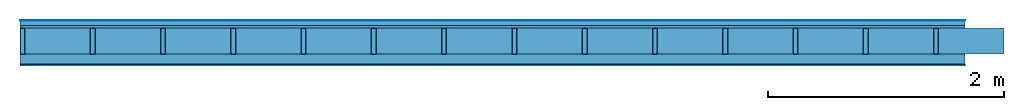
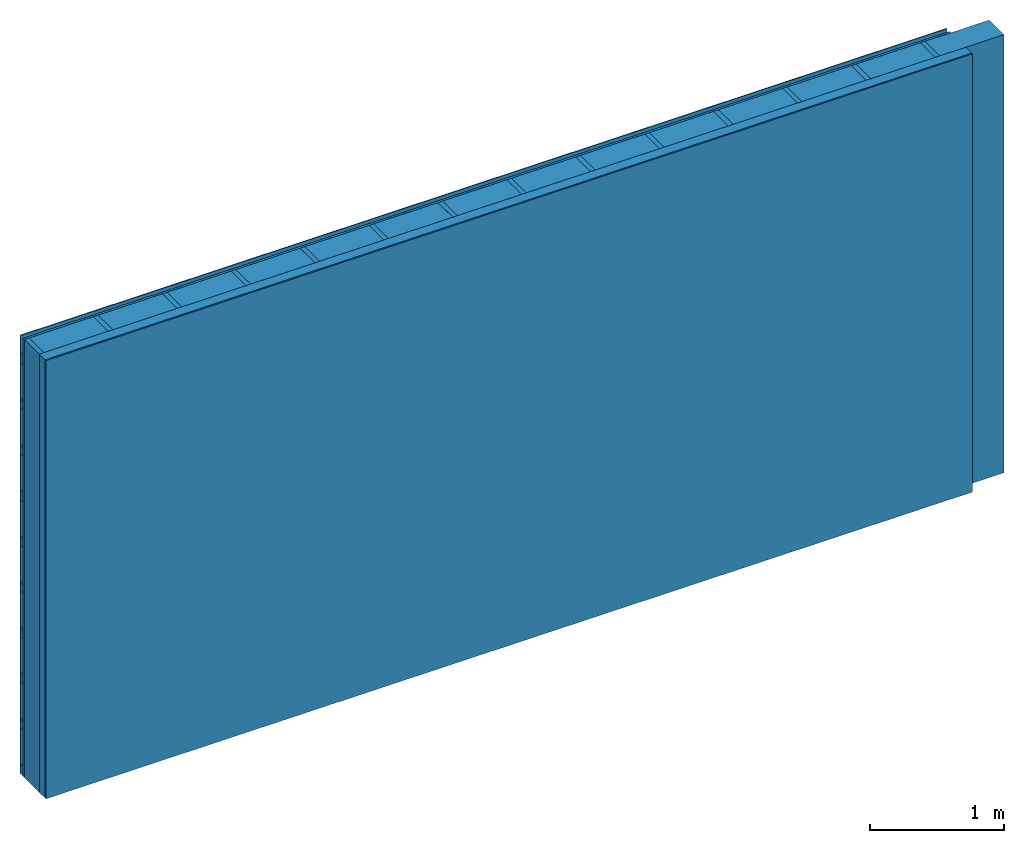
# One storey: 4 plates, 3 members, 1 element without a shape of its own.
"""IFC4 building model written with IfcOpenShell, lengths in metres."""

from ifc_helpers import new_model, si_unit, derived_unit, direction, frame, frame_2d, origin, origin_with_axes, place, context, project, spatial, rectangle, extrude, material, layer, layer_set, type_object, element, aggregate, save


model = new_model("IFC4")

# Units and contexts
plan_context = context("Plan", 3, precision=1e-05, world=origin(), true_north=direction((0.0, 1.0)))
model_context = context("Model", 3, precision=1e-05, world=origin(), true_north=direction((0.0, 1.0)))
ifc_project = project(units=[si_unit("LENGTHUNIT", "METRE"), derived_unit("SOUNDPRESSUREUNIT", [(si_unit("PRESSUREUNIT", "PASCAL", prefix="MICRO"), 0)]), si_unit("ENERGYUNIT", "JOULE", prefix="MEGA"), si_unit("MASSUNIT", "GRAM", prefix="KILO"), derived_unit("THERMALTRANSMITTANCEUNIT", [(si_unit("POWERUNIT", "WATT"), 1), (si_unit("AREAUNIT", "SQUARE_METRE"), -1), (si_unit("THERMODYNAMICTEMPERATUREUNIT", "KELVIN"), -1)]), derived_unit("AREADENSITYUNIT", [(si_unit("MASSUNIT", "GRAM", prefix="KILO"), 1), (si_unit("AREAUNIT", "SQUARE_METRE"), -1)]), derived_unit("USERDEFINED", [(si_unit("ENERGYUNIT", "JOULE", prefix="MEGA"), 1), (si_unit("AREAUNIT", "SQUARE_METRE"), -1)])], contexts=[plan_context, model_context])

# Site, building, storey
site = spatial("IfcSite", under=ifc_project)
building_placement = place(None, origin())
building = spatial("IfcBuilding", under=site, at=building_placement)
storey_placement = place(building_placement, origin())
storey = spatial("IfcBuildingStorey", under=building, at=storey_placement)

# Wall, members, plates
ifc_material_1 = material(Name="mineral, cement-based building board", Category="03.003")
ifc_layer_1 = layer(ifc_material_1, 0.008, Name="Cover 1st layer")
ifc_layer_2 = layer(None, 0.04, Name="Battens / profiles (ventilation)")
ifc_material_2 = material(Category="10.009")
ifc_layer_3 = layer(ifc_material_2, 0.02, Name="outside 1st layer")
ifc_material_3 = material(Name="of the art")
ifc_layer_4 = layer(ifc_material_3, 0.0, Name="Bond")
ifc_layer_5 = layer(None, 0.22, Name="Support")
ifc_layer_6 = layer(ifc_material_3, 0.0, Name="Bond")
ifc_material_4 = material(Name="Solid timber panel")
ifc_layer_7 = layer(ifc_material_4, 0.087, Name="1st layer")
ifc_material_5 = material(Name="Plasterboard type A", Category="03.008")
ifc_layer_8 = layer(ifc_material_5, 0.0125, Name="Covering 1st layer")
ifc_material_6 = material(Name="joints", Category="04.017")
ifc_layer_9 = layer(ifc_material_6, 0.0, Name="Surface")
ifc_layer_set = layer_set([ifc_layer_1, ifc_layer_2, ifc_layer_3, ifc_layer_4, ifc_layer_5, ifc_layer_6, ifc_layer_7, ifc_layer_8, ifc_layer_9])
wall_type = type_object("IfcWallType", Name="D0971", PredefinedType="NOTDEFINED", material=ifc_layer_set)
wall_placement = place(None, frame((0.0, 0.0, 0.0), z_axis=(0.0, -1.0, 0.0), x_axis=(1.0, 0.0, 0.0)))
wall = element("IfcWall", 1, at=wall_placement, inside=storey, type_object=wall_type, material=ifc_layer_set, Name="Wall #1")
ifc_material_7 = material()
member_1_placement = place(wall_placement, origin())
member_1 = element("IfcMember", 2, at=member_1_placement, material=ifc_material_7, Name="Battens / profiles (ventilation)", context=plan_context, shape_type="SweptSolid", body=[
    extrude(rectangle(XDim=0.08, YDim=0.04, at=frame_2d((0.04, 0.02), x_axis=(1.0, 0.0))), frame((0.0, 0.0, 0.008), z_axis=(1.0, 0.0, 0.0), x_axis=(0.0, 1.0, 0.0)), (0.0, 0.0, 1.0), 8.0),
    extrude(rectangle(XDim=0.08, YDim=0.04, at=frame_2d((0.04, 0.02), x_axis=(1.0, 0.0))), frame((0.0, 0.417, 0.008), z_axis=(1.0, 0.0, 0.0), x_axis=(0.0, 1.0, 0.0)), (0.0, 0.0, 1.0), 8.0),
    extrude(rectangle(XDim=0.08, YDim=0.04, at=frame_2d((0.04, 0.02), x_axis=(1.0, 0.0))), frame((0.0, 0.834, 0.008), z_axis=(1.0, 0.0, 0.0), x_axis=(0.0, 1.0, 0.0)), (0.0, 0.0, 1.0), 8.0),
    extrude(rectangle(XDim=0.08, YDim=0.04, at=frame_2d((0.04, 0.02), x_axis=(1.0, 0.0))), frame((0.0, 1.251, 0.008), z_axis=(1.0, 0.0, 0.0), x_axis=(0.0, 1.0, 0.0)), (0.0, 0.0, 1.0), 8.0),
    extrude(rectangle(XDim=0.08, YDim=0.04, at=frame_2d((0.04, 0.02), x_axis=(1.0, 0.0))), frame((0.0, 1.668, 0.008), z_axis=(1.0, 0.0, 0.0), x_axis=(0.0, 1.0, 0.0)), (0.0, 0.0, 1.0), 8.0),
    extrude(rectangle(XDim=0.08, YDim=0.04, at=frame_2d((0.04, 0.02), x_axis=(1.0, 0.0))), frame((0.0, 2.085, 0.008), z_axis=(1.0, 0.0, 0.0), x_axis=(0.0, 1.0, 0.0)), (0.0, 0.0, 1.0), 8.0),
    extrude(rectangle(XDim=0.08, YDim=0.04, at=frame_2d((0.04, 0.02), x_axis=(1.0, 0.0))), frame((0.0, 2.502, 0.008), z_axis=(1.0, 0.0, 0.0), x_axis=(0.0, 1.0, 0.0)), (0.0, 0.0, 1.0), 8.0),
    extrude(rectangle(XDim=0.08, YDim=0.04, at=frame_2d((0.04, 0.02), x_axis=(1.0, 0.0))), frame((0.0, 2.919, 0.008), z_axis=(1.0, 0.0, 0.0), x_axis=(0.0, 1.0, 0.0)), (0.0, 0.0, 1.0), 8.0),
    extrude(rectangle(XDim=0.08, YDim=0.04, at=frame_2d((0.04, 0.02), x_axis=(1.0, 0.0))), frame((0.0, 3.336, 0.008), z_axis=(1.0, 0.0, 0.0), x_axis=(0.0, 1.0, 0.0)), (0.0, 0.0, 1.0), 8.0),
    extrude(rectangle(XDim=0.08, YDim=0.04, at=frame_2d((0.04, 0.02), x_axis=(1.0, 0.0))), frame((0.0, 3.753, 0.008), z_axis=(1.0, 0.0, 0.0), x_axis=(0.0, 1.0, 0.0)), (0.0, 0.0, 1.0), 8.0),
])
ifc_material_8 = material()
member_2_placement = place(wall_placement, origin())
member_2 = element("IfcMember", 3, at=member_2_placement, material=ifc_material_8, Name="Support", context=plan_context, shape_type="SweptSolid", body=[
    extrude(rectangle(XDim=0.04, YDim=0.22, at=frame_2d((0.02, 0.11), x_axis=(1.0, 0.0))), frame((0.0, 4.0, 0.068), z_axis=(0.0, -1.0, 0.0), x_axis=(1.0, 0.0, 0.0)), (0.0, 0.0, 1.0), 4.0),
    extrude(rectangle(XDim=0.04, YDim=0.22, at=frame_2d((0.02, 0.11), x_axis=(1.0, 0.0))), frame((0.595, 4.0, 0.068), z_axis=(0.0, -1.0, 0.0), x_axis=(1.0, 0.0, 0.0)), (0.0, 0.0, 1.0), 4.0),
    extrude(rectangle(XDim=0.04, YDim=0.22, at=frame_2d((0.02, 0.11), x_axis=(1.0, 0.0))), frame((1.19, 4.0, 0.068), z_axis=(0.0, -1.0, 0.0), x_axis=(1.0, 0.0, 0.0)), (0.0, 0.0, 1.0), 4.0),
    extrude(rectangle(XDim=0.04, YDim=0.22, at=frame_2d((0.02, 0.11), x_axis=(1.0, 0.0))), frame((1.785, 4.0, 0.068), z_axis=(0.0, -1.0, 0.0), x_axis=(1.0, 0.0, 0.0)), (0.0, 0.0, 1.0), 4.0),
    extrude(rectangle(XDim=0.04, YDim=0.22, at=frame_2d((0.02, 0.11), x_axis=(1.0, 0.0))), frame((2.38, 4.0, 0.068), z_axis=(0.0, -1.0, 0.0), x_axis=(1.0, 0.0, 0.0)), (0.0, 0.0, 1.0), 4.0),
    extrude(rectangle(XDim=0.04, YDim=0.22, at=frame_2d((0.02, 0.11), x_axis=(1.0, 0.0))), frame((2.975, 4.0, 0.068), z_axis=(0.0, -1.0, 0.0), x_axis=(1.0, 0.0, 0.0)), (0.0, 0.0, 1.0), 4.0),
    extrude(rectangle(XDim=0.04, YDim=0.22, at=frame_2d((0.02, 0.11), x_axis=(1.0, 0.0))), frame((3.57, 4.0, 0.068), z_axis=(0.0, -1.0, 0.0), x_axis=(1.0, 0.0, 0.0)), (0.0, 0.0, 1.0), 4.0),
    extrude(rectangle(XDim=0.04, YDim=0.22, at=frame_2d((0.02, 0.11), x_axis=(1.0, 0.0))), frame((4.165, 4.0, 0.068), z_axis=(0.0, -1.0, 0.0), x_axis=(1.0, 0.0, 0.0)), (0.0, 0.0, 1.0), 4.0),
    extrude(rectangle(XDim=0.04, YDim=0.22, at=frame_2d((0.02, 0.11), x_axis=(1.0, 0.0))), frame((4.76, 4.0, 0.068), z_axis=(0.0, -1.0, 0.0), x_axis=(1.0, 0.0, 0.0)), (0.0, 0.0, 1.0), 4.0),
    extrude(rectangle(XDim=0.04, YDim=0.22, at=frame_2d((0.02, 0.11), x_axis=(1.0, 0.0))), frame((5.355, 4.0, 0.068), z_axis=(0.0, -1.0, 0.0), x_axis=(1.0, 0.0, 0.0)), (0.0, 0.0, 1.0), 4.0),
    extrude(rectangle(XDim=0.04, YDim=0.22, at=frame_2d((0.02, 0.11), x_axis=(1.0, 0.0))), frame((5.95, 4.0, 0.068), z_axis=(0.0, -1.0, 0.0), x_axis=(1.0, 0.0, 0.0)), (0.0, 0.0, 1.0), 4.0),
    extrude(rectangle(XDim=0.04, YDim=0.22, at=frame_2d((0.02, 0.11), x_axis=(1.0, 0.0))), frame((6.545, 4.0, 0.068), z_axis=(0.0, -1.0, 0.0), x_axis=(1.0, 0.0, 0.0)), (0.0, 0.0, 1.0), 4.0),
    extrude(rectangle(XDim=0.04, YDim=0.22, at=frame_2d((0.02, 0.11), x_axis=(1.0, 0.0))), frame((7.14, 4.0, 0.068), z_axis=(0.0, -1.0, 0.0), x_axis=(1.0, 0.0, 0.0)), (0.0, 0.0, 1.0), 4.0),
    extrude(rectangle(XDim=0.04, YDim=0.22, at=frame_2d((0.02, 0.11), x_axis=(1.0, 0.0))), frame((7.735, 4.0, 0.068), z_axis=(0.0, -1.0, 0.0), x_axis=(1.0, 0.0, 0.0)), (0.0, 0.0, 1.0), 4.0),
])
ifc_material_9 = material()
member_3_placement = place(wall_placement, origin())
member_3 = element("IfcMember", 4, at=member_3_placement, material=ifc_material_9, Name="Cavity", context=plan_context, shape_type="SweptSolid", body=[
    extrude(rectangle(XDim=0.555, YDim=0.22, at=frame_2d((0.2775, 0.11), x_axis=(1.0, 0.0))), frame((0.04, 4.0, 0.068), z_axis=(0.0, -1.0, 0.0), x_axis=(1.0, 0.0, 0.0)), (0.0, 0.0, 1.0), 4.0),
    extrude(rectangle(XDim=0.555, YDim=0.22, at=frame_2d((0.2775, 0.11), x_axis=(1.0, 0.0))), frame((0.635, 4.0, 0.068), z_axis=(0.0, -1.0, 0.0), x_axis=(1.0, 0.0, 0.0)), (0.0, 0.0, 1.0), 4.0),
    extrude(rectangle(XDim=0.555, YDim=0.22, at=frame_2d((0.2775, 0.11), x_axis=(1.0, 0.0))), frame((1.23, 4.0, 0.068), z_axis=(0.0, -1.0, 0.0), x_axis=(1.0, 0.0, 0.0)), (0.0, 0.0, 1.0), 4.0),
    extrude(rectangle(XDim=0.555, YDim=0.22, at=frame_2d((0.2775, 0.11), x_axis=(1.0, 0.0))), frame((1.825, 4.0, 0.068), z_axis=(0.0, -1.0, 0.0), x_axis=(1.0, 0.0, 0.0)), (0.0, 0.0, 1.0), 4.0),
    extrude(rectangle(XDim=0.555, YDim=0.22, at=frame_2d((0.2775, 0.11), x_axis=(1.0, 0.0))), frame((2.42, 4.0, 0.068), z_axis=(0.0, -1.0, 0.0), x_axis=(1.0, 0.0, 0.0)), (0.0, 0.0, 1.0), 4.0),
    extrude(rectangle(XDim=0.555, YDim=0.22, at=frame_2d((0.2775, 0.11), x_axis=(1.0, 0.0))), frame((3.015, 4.0, 0.068), z_axis=(0.0, -1.0, 0.0), x_axis=(1.0, 0.0, 0.0)), (0.0, 0.0, 1.0), 4.0),
    extrude(rectangle(XDim=0.555, YDim=0.22, at=frame_2d((0.2775, 0.11), x_axis=(1.0, 0.0))), frame((3.61, 4.0, 0.068), z_axis=(0.0, -1.0, 0.0), x_axis=(1.0, 0.0, 0.0)), (0.0, 0.0, 1.0), 4.0),
    extrude(rectangle(XDim=0.555, YDim=0.22, at=frame_2d((0.2775, 0.11), x_axis=(1.0, 0.0))), frame((4.205, 4.0, 0.068), z_axis=(0.0, -1.0, 0.0), x_axis=(1.0, 0.0, 0.0)), (0.0, 0.0, 1.0), 4.0),
    extrude(rectangle(XDim=0.555, YDim=0.22, at=frame_2d((0.2775, 0.11), x_axis=(1.0, 0.0))), frame((4.8, 4.0, 0.068), z_axis=(0.0, -1.0, 0.0), x_axis=(1.0, 0.0, 0.0)), (0.0, 0.0, 1.0), 4.0),
    extrude(rectangle(XDim=0.555, YDim=0.22, at=frame_2d((0.2775, 0.11), x_axis=(1.0, 0.0))), frame((5.395, 4.0, 0.068), z_axis=(0.0, -1.0, 0.0), x_axis=(1.0, 0.0, 0.0)), (0.0, 0.0, 1.0), 4.0),
    extrude(rectangle(XDim=0.555, YDim=0.22, at=frame_2d((0.2775, 0.11), x_axis=(1.0, 0.0))), frame((5.99, 4.0, 0.068), z_axis=(0.0, -1.0, 0.0), x_axis=(1.0, 0.0, 0.0)), (0.0, 0.0, 1.0), 4.0),
    extrude(rectangle(XDim=0.555, YDim=0.22, at=frame_2d((0.2775, 0.11), x_axis=(1.0, 0.0))), frame((6.585, 4.0, 0.068), z_axis=(0.0, -1.0, 0.0), x_axis=(1.0, 0.0, 0.0)), (0.0, 0.0, 1.0), 4.0),
    extrude(rectangle(XDim=0.555, YDim=0.22, at=frame_2d((0.2775, 0.11), x_axis=(1.0, 0.0))), frame((7.18, 4.0, 0.068), z_axis=(0.0, -1.0, 0.0), x_axis=(1.0, 0.0, 0.0)), (0.0, 0.0, 1.0), 4.0),
    extrude(rectangle(XDim=0.555, YDim=0.22, at=frame_2d((0.2775, 0.11), x_axis=(1.0, 0.0))), frame((7.775, 4.0, 0.068), z_axis=(0.0, -1.0, 0.0), x_axis=(1.0, 0.0, 0.0)), (0.0, 0.0, 1.0), 4.0),
])
plate_1_placement = place(wall_placement, origin())
plate_1 = element("IfcPlate", 5, at=plate_1_placement, material=ifc_material_1, Name="Cover 1st layer", context=plan_context, shape_type="SweptSolid", body=[
    extrude(rectangle(XDim=8.0, YDim=4.0, at=frame_2d((4.0, 2.0), x_axis=(1.0, 0.0))), origin_with_axes(), (0.0, 0.0, 1.0), 0.008),
])
plate_2_placement = place(wall_placement, origin())
plate_2 = element("IfcPlate", 6, at=plate_2_placement, material=ifc_material_2, Name="outside 1st layer", context=plan_context, shape_type="SweptSolid", body=[
    extrude(rectangle(XDim=8.0, YDim=4.0, at=frame_2d((4.0, 2.0), x_axis=(1.0, 0.0))), frame((0.0, 0.0, 0.048), z_axis=(0.0, 0.0, 1.0), x_axis=(1.0, 0.0, 0.0)), (0.0, 0.0, 1.0), 0.02),
])
plate_3_placement = place(wall_placement, origin())
plate_3 = element("IfcPlate", 7, at=plate_3_placement, material=ifc_material_4, Name="1st layer", context=plan_context, shape_type="SweptSolid", body=[
    extrude(rectangle(XDim=8.0, YDim=4.0, at=frame_2d((4.0, 2.0), x_axis=(1.0, 0.0))), frame((0.0, 0.0, 0.288), z_axis=(0.0, 0.0, 1.0), x_axis=(1.0, 0.0, 0.0)), (0.0, 0.0, 1.0), 0.087),
])
plate_4_placement = place(wall_placement, origin())
plate_4 = element("IfcPlate", 8, at=plate_4_placement, material=ifc_material_5, Name="Covering 1st layer", context=plan_context, shape_type="SweptSolid", body=[
    extrude(rectangle(XDim=8.0, YDim=4.0, at=frame_2d((4.0, 2.0), x_axis=(1.0, 0.0))), frame((0.0, 0.0, 0.375), z_axis=(0.0, 0.0, 1.0), x_axis=(1.0, 0.0, 0.0)), (0.0, 0.0, 1.0), 0.0125),
])
aggregate(wall, [plate_1, member_1, plate_2, member_2, member_3, plate_3, plate_4])

save(model, "model.ifc")
